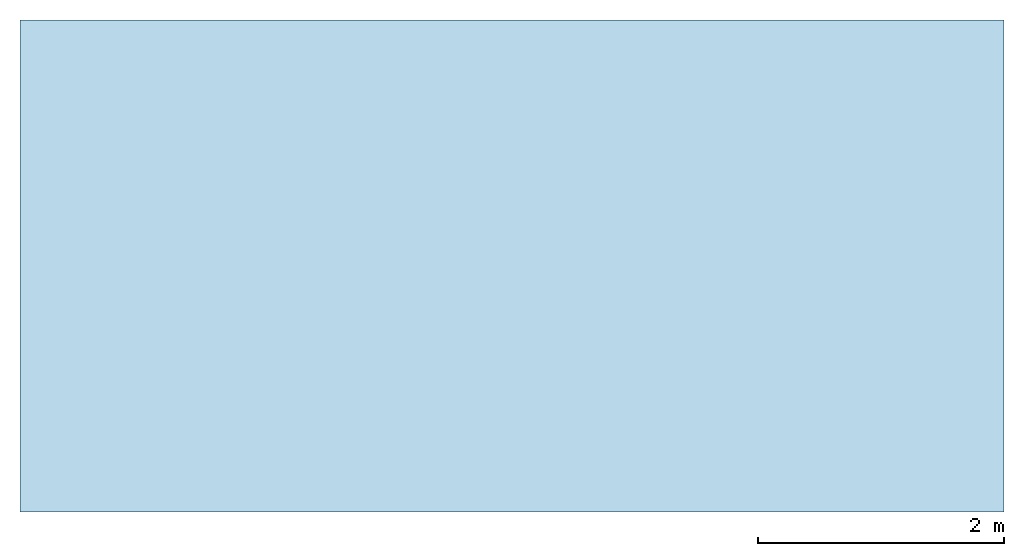
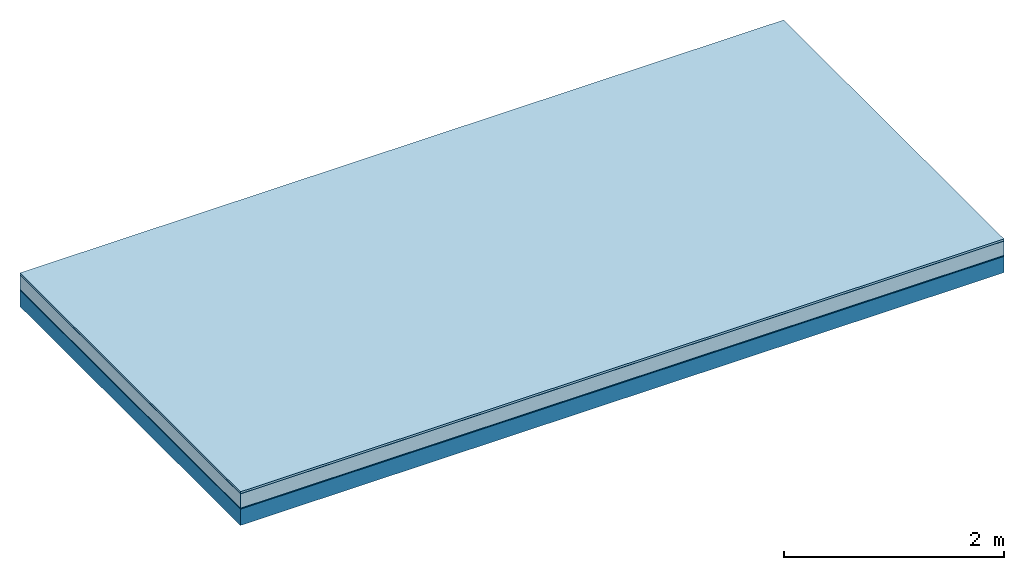
# One storey: 5 plates, 1 member, 1 element without a shape of its own.
"""IFC4 building model written with IfcOpenShell, lengths in metres."""

import ifcopenshell
import ifcopenshell.guid

model = None  # the IFC model being written
_history = None  # IfcOwnerHistory: only IFC2X3 demands one
_inside = {}  # id of a spatial element -> (the spatial element, [elements in it])
_under = {}  # id of a project, library or spatial element -> (it, [spatial elements below it])
_declared = {}  # id of a project -> (the project, [libraries it declares])
_typed = {}  # id of a type object -> (the type object, [elements of that type])
_made_of = {}  # id of a material, layer set ... -> (it, [elements and type objects made of it])


def new_model(schema):
    """Start an empty IFC model of exactly this schema.

    Asked for "IFC4X3", IfcOpenShell would pick the latest addendum, in which some entities
    have other attributes; the version numbers below select the first issue.
    IFC2X3 requires an IfcOwnerHistory on every rooted entity: one is made here for all.
    """
    global model, _history
    if schema == "IFC4X3":
        model = ifcopenshell.file(schema_version=(4, 3, 0, 0))
    else:
        model = ifcopenshell.file(schema=schema)
    _inside.clear()
    _under.clear()
    _declared.clear()
    _typed.clear()
    _made_of.clear()
    _history = None
    if model.schema == "IFC2X3":
        org = make("IfcOrganization", Name="unknown")
        user = make(
            "IfcPersonAndOrganization",
            ThePerson=make("IfcPerson", FamilyName="unknown"),
            TheOrganization=org,
        )
        app = make(
            "IfcApplication",
            ApplicationDeveloper=org,
            Version="unknown",
            ApplicationFullName="unknown",
            ApplicationIdentifier="unknown",
        )
        _history = make(
            "IfcOwnerHistory",
            OwningUser=user,
            OwningApplication=app,
            ChangeAction="ADDED",
            CreationDate=0,
        )
    return model


def make(cls, **values):
    """One entity of the class cls with the attributes given. An attribute that is None is left unset."""
    return model.create_entity(
        cls, **{name: value for name, value in values.items() if value is not None}
    )


def rooted(cls, **values):
    """An entity with a GlobalId (a new one), such as an element, a storey or a relation."""
    return make(cls, GlobalId=ifcopenshell.guid.new(), OwnerHistory=_history, **values)


def si_unit(unit_type, name, prefix=None):
    """IfcSIUnit, for example si_unit("LENGTHUNIT", "METRE", prefix="MILLI")."""
    return make("IfcSIUnit", UnitType=unit_type, Prefix=prefix, Name=name)


def derived_unit(unit_type, elements):
    """IfcDerivedUnit: a product of units, each with its exponent."""
    return make(
        "IfcDerivedUnit",
        Elements=[
            make("IfcDerivedUnitElement", Unit=unit, Exponent=power)
            for unit, power in elements
        ],
        UnitType=unit_type,
    )


def assignment(units):
    """IfcUnitAssignment: the units of a project."""
    return None if units is None else make("IfcUnitAssignment", Units=units)


def point(xyz):
    """IfcCartesianPoint."""
    return None if xyz is None else make("IfcCartesianPoint", Coordinates=xyz)


def direction(xyz):
    """IfcDirection."""
    return None if xyz is None else make("IfcDirection", DirectionRatios=xyz)


def frame(location, z_axis=None, x_axis=None):
    """IfcAxis2Placement3D, a coordinate frame: its origin and axes. An axis left out is left unset."""
    return make(
        "IfcAxis2Placement3D",
        Location=point(location),
        Axis=direction(z_axis),
        RefDirection=direction(x_axis),
    )


def frame_2d(location, x_axis=None):
    """IfcAxis2Placement2D, a coordinate frame in the plane: its origin and x axis."""
    return make(
        "IfcAxis2Placement2D", Location=point(location), RefDirection=direction(x_axis)
    )


def origin():
    """The frame at (0, 0, 0) with its axes left unset."""
    return frame((0.0, 0.0, 0.0))


def origin_with_axes():
    """The frame at (0, 0, 0) with the z axis (0, 0, 1) and the x axis (1, 0, 0) written out."""
    return frame((0.0, 0.0, 0.0), z_axis=(0.0, 0.0, 1.0), x_axis=(1.0, 0.0, 0.0))


def place(relative_to, where):
    """IfcLocalPlacement: puts the frame where relative to a parent placement (None: the world)."""
    return make(
        "IfcLocalPlacement", PlacementRelTo=relative_to, RelativePlacement=where
    )


def context(
    kind, dimensions, precision=None, world=None, true_north=None, identifier=None
):
    """IfcGeometricRepresentationContext, for example the 3D "Model" context."""
    return make(
        "IfcGeometricRepresentationContext",
        ContextIdentifier=identifier,
        ContextType=kind,
        CoordinateSpaceDimension=dimensions,
        Precision=precision,
        WorldCoordinateSystem=world,
        TrueNorth=true_north,
    )


def project(units=None, contexts=None):
    """IfcProject with its units and contexts."""
    return rooted(
        "IfcProject",
        Name="project",
        RepresentationContexts=contexts,
        UnitsInContext=assignment(units),
    )


def spatial(cls, under=None, at=None, **own):
    """A site, building, storey or space (cls), placed at a placement, below another one or the project."""
    s = rooted(cls, ObjectPlacement=at, **own)
    if under is not None:
        _under.setdefault(under.id(), (under, []))[1].append(s)
    return s


def profile(cls, at=None, kind="AREA", **sizes):
    """A parametric profile (cls). Its sizes go by their IFC names, for example OverallWidth=200.0."""
    return make(cls, ProfileType=kind, Position=at, **sizes)


def rectangle(**sizes):
    """IfcRectangleProfileDef."""
    return profile("IfcRectangleProfileDef", **sizes)


def extrude(swept, where, along, depth):
    """IfcExtrudedAreaSolid: the profile swept, set in the frame where, extruded along a direction by depth."""
    return make(
        "IfcExtrudedAreaSolid",
        SweptArea=swept,
        Position=where,
        ExtrudedDirection=direction(along),
        Depth=depth,
    )


def shape(context_of_items, identifier, shape_type, items):
    """IfcShapeRepresentation: the items that make up one representation, for example the "Body"."""
    return make(
        "IfcShapeRepresentation",
        ContextOfItems=context_of_items,
        RepresentationIdentifier=identifier,
        RepresentationType=shape_type,
        Items=items,
    )


def material(Name=None, Category=None):
    """IfcMaterial."""
    return make("IfcMaterial", Name=Name, Category=Category)


def layer(
    of_material, thickness, ventilated=None, Name=None, Category=None, Priority=None
):
    """IfcMaterialLayer: one layer of a wall or slab, of a material (None: an air gap)."""
    return make(
        "IfcMaterialLayer",
        Material=of_material,
        LayerThickness=thickness,
        IsVentilated=ventilated,
        Name=Name,
        Category=Category,
        Priority=Priority,
    )


def layer_set(layers, Name=None):
    """IfcMaterialLayerSet."""
    return make("IfcMaterialLayerSet", MaterialLayers=layers, LayerSetName=Name)


def made_of(thing, what):
    """Note that an element or type object is made of a material, layer set ...; save() writes the relation."""
    if what is not None:
        _made_of.setdefault(what.id(), (what, []))[1].append(thing)
    return thing


def type_object(cls, material=None, **own):
    """A type object (cls), such as IfcWallType, which elements share."""
    return made_of(rooted(cls, **own), material)


def element(
    cls,
    number,
    at=None,
    inside=None,
    cuts=None,
    type_object=None,
    material=None,
    context=None,
    identifier="Body",
    shape_type=None,
    held_by="IfcProductDefinitionShape",
    body=None,
    shapes=None,
    **own,
):
    """One element of the class cls, such as IfcWall. Its Tag is "e" and its number.

    at: its placement. inside: the storey or other place that contains it. cuts: it is an
    opening in that element (IfcRelVoidsElement). A single representation is given by context,
    identifier, shape_type and body (its items); several are given by shapes. held_by: the class
    of the entity that holds the representations. save() writes the other relations.
    """
    e = rooted(cls, Tag="e%d" % number, ObjectPlacement=at, **own)
    if body is not None:
        shapes = [shape(context, identifier, shape_type, body)]
    if shapes is not None:
        e.Representation = make(held_by, Representations=shapes)
    if inside is not None:
        _inside.setdefault(inside.id(), (inside, []))[1].append(e)
    if cuts is not None:
        rooted(
            "IfcRelVoidsElement", RelatingBuildingElement=cuts, RelatedOpeningElement=e
        )
    if type_object is not None:
        _typed.setdefault(type_object.id(), (type_object, []))[1].append(e)
    return made_of(e, material)


def aggregate(whole, parts):
    """IfcRelAggregates: a whole, such as a stair, and the parts it consists of."""
    return rooted("IfcRelAggregates", RelatingObject=whole, RelatedObjects=parts)


def save(model, path):
    """Write the relations noted so far, then the file.

    IfcRelAggregates (storeys below a building ...), IfcRelContainedInSpatialStructure (elements
    in a storey), IfcRelDefinesByType, IfcRelAssociatesMaterial and IfcRelDeclares: one each for
    every whole, place, type object, material and project.
    """
    for whole, parts in _under.values():
        aggregate(whole, parts)
    for where, things in _inside.values():
        rooted(
            "IfcRelContainedInSpatialStructure",
            RelatedElements=things,
            RelatingStructure=where,
        )
    for kind, things in _typed.values():
        rooted("IfcRelDefinesByType", RelatedObjects=things, RelatingType=kind)
    for what, things in _made_of.values():
        rooted("IfcRelAssociatesMaterial", RelatedObjects=things, RelatingMaterial=what)
    for by, libraries in _declared.values():
        rooted("IfcRelDeclares", RelatingContext=by, RelatedDefinitions=libraries)
    model.write(path)


model = new_model("IFC4")

# Units and contexts
plan_context = context("Plan", 3, precision=1e-05, world=origin(), true_north=direction((0.0, 1.0)))
model_context = context("Model", 3, precision=1e-05, world=origin(), true_north=direction((0.0, 1.0)))
ifc_project = project(units=[si_unit("LENGTHUNIT", "METRE"), derived_unit("SOUNDPRESSUREUNIT", [(si_unit("PRESSUREUNIT", "PASCAL", prefix="MICRO"), 0)]), si_unit("ENERGYUNIT", "JOULE", prefix="MEGA"), si_unit("MASSUNIT", "GRAM", prefix="KILO"), derived_unit("THERMALTRANSMITTANCEUNIT", [(si_unit("POWERUNIT", "WATT"), 1), (si_unit("AREAUNIT", "SQUARE_METRE"), -1), (si_unit("THERMODYNAMICTEMPERATUREUNIT", "KELVIN"), -1)]), derived_unit("AREADENSITYUNIT", [(si_unit("MASSUNIT", "GRAM", prefix="KILO"), 1), (si_unit("AREAUNIT", "SQUARE_METRE"), -1)]), derived_unit("USERDEFINED", [(si_unit("ENERGYUNIT", "JOULE", prefix="MEGA"), 1), (si_unit("AREAUNIT", "SQUARE_METRE"), -1)])], contexts=[plan_context, model_context])

# Site, building, storey
site = spatial("IfcSite", under=ifc_project)
building_placement = place(None, origin())
building = spatial("IfcBuilding", under=site, at=building_placement)
storey_placement = place(building_placement, origin())
storey = spatial("IfcBuildingStorey", under=building, at=storey_placement)

# Slab, member, plates
ifc_material_1 = material(Name="with tongue and groove", Category="07.009")
ifc_layer_1 = layer(ifc_material_1, 0.022, Name="Flooring")
ifc_material_2 = material(Category="09.006")
ifc_layer_2 = layer(ifc_material_2, 0.0005, Name="layer")
ifc_material_3 = material(Name="2x 60x80mm")
ifc_layer_3 = layer(ifc_material_3, 0.16, Name="On-material")
ifc_material_4 = material(Name="Wood fiber generic product", Category="10.009")
ifc_layer_4 = layer(ifc_material_4, 0.01, Name="Impact sound insulation")
ifc_material_5 = material(Name="protection", Category="09.007")
ifc_layer_5 = layer(ifc_material_5, 0.0005, Name="Sub-floor")
ifc_material_6 = material(Name="no composite action")
ifc_layer_6 = layer(ifc_material_6, 0.0, Name="Bond")
ifc_layer_7 = layer(None, 0.18, Name="Supporting structure")
ifc_layer_set = layer_set([ifc_layer_1, ifc_layer_2, ifc_layer_3, ifc_layer_4, ifc_layer_5, ifc_layer_6, ifc_layer_7])
slab_type = type_object("IfcSlabType", Name="A2027", PredefinedType="NOTDEFINED", material=ifc_layer_set)
slab_placement = place(None, frame((0.0, 0.0, 0.0), z_axis=(0.0, 0.0, -1.0), x_axis=(1.0, 0.0, 0.0)))
slab = element("IfcSlab", 1, at=slab_placement, inside=storey, type_object=slab_type, material=ifc_layer_set, Name="Slab #1")
ifc_material_7 = material(Name="Solid timber panel")
member_placement = place(slab_placement, origin())
member = element("IfcMember", 2, at=member_placement, material=ifc_material_7, Name="Supporting structure", context=plan_context, shape_type="SweptSolid", body=[
    extrude(rectangle(XDim=1.0, YDim=0.18, at=frame_2d((0.5, 0.09), x_axis=(1.0, 0.0))), frame((0.0, 4.0, 0.193), z_axis=(0.0, -1.0, 0.0), x_axis=(1.0, 0.0, 0.0)), (0.0, 0.0, 1.0), 4.0),
    extrude(rectangle(XDim=1.0, YDim=0.18, at=frame_2d((0.5, 0.09), x_axis=(1.0, 0.0))), frame((1.0, 4.0, 0.193), z_axis=(0.0, -1.0, 0.0), x_axis=(1.0, 0.0, 0.0)), (0.0, 0.0, 1.0), 4.0),
    extrude(rectangle(XDim=1.0, YDim=0.18, at=frame_2d((0.5, 0.09), x_axis=(1.0, 0.0))), frame((2.0, 4.0, 0.193), z_axis=(0.0, -1.0, 0.0), x_axis=(1.0, 0.0, 0.0)), (0.0, 0.0, 1.0), 4.0),
    extrude(rectangle(XDim=1.0, YDim=0.18, at=frame_2d((0.5, 0.09), x_axis=(1.0, 0.0))), frame((3.0, 4.0, 0.193), z_axis=(0.0, -1.0, 0.0), x_axis=(1.0, 0.0, 0.0)), (0.0, 0.0, 1.0), 4.0),
    extrude(rectangle(XDim=1.0, YDim=0.18, at=frame_2d((0.5, 0.09), x_axis=(1.0, 0.0))), frame((4.0, 4.0, 0.193), z_axis=(0.0, -1.0, 0.0), x_axis=(1.0, 0.0, 0.0)), (0.0, 0.0, 1.0), 4.0),
    extrude(rectangle(XDim=1.0, YDim=0.18, at=frame_2d((0.5, 0.09), x_axis=(1.0, 0.0))), frame((5.0, 4.0, 0.193), z_axis=(0.0, -1.0, 0.0), x_axis=(1.0, 0.0, 0.0)), (0.0, 0.0, 1.0), 4.0),
    extrude(rectangle(XDim=1.0, YDim=0.18, at=frame_2d((0.5, 0.09), x_axis=(1.0, 0.0))), frame((6.0, 4.0, 0.193), z_axis=(0.0, -1.0, 0.0), x_axis=(1.0, 0.0, 0.0)), (0.0, 0.0, 1.0), 4.0),
    extrude(rectangle(XDim=1.0, YDim=0.18, at=frame_2d((0.5, 0.09), x_axis=(1.0, 0.0))), frame((7.0, 4.0, 0.193), z_axis=(0.0, -1.0, 0.0), x_axis=(1.0, 0.0, 0.0)), (0.0, 0.0, 1.0), 4.0),
])
plate_1_placement = place(slab_placement, origin())
plate_1 = element("IfcPlate", 3, at=plate_1_placement, material=ifc_material_1, Name="Flooring", context=plan_context, shape_type="SweptSolid", body=[
    extrude(rectangle(XDim=8.0, YDim=4.0, at=frame_2d((4.0, 2.0), x_axis=(1.0, 0.0))), origin_with_axes(), (0.0, 0.0, 1.0), 0.022),
])
plate_2_placement = place(slab_placement, origin())
plate_2 = element("IfcPlate", 4, at=plate_2_placement, material=ifc_material_2, Name="layer", context=plan_context, shape_type="SweptSolid", body=[
    extrude(rectangle(XDim=8.0, YDim=4.0, at=frame_2d((4.0, 2.0), x_axis=(1.0, 0.0))), frame((0.0, 0.0, 0.022), z_axis=(0.0, 0.0, 1.0), x_axis=(1.0, 0.0, 0.0)), (0.0, 0.0, 1.0), 0.0005),
])
plate_3_placement = place(slab_placement, origin())
plate_3 = element("IfcPlate", 5, at=plate_3_placement, material=ifc_material_3, Name="On-material", context=plan_context, shape_type="SweptSolid", body=[
    extrude(rectangle(XDim=8.0, YDim=4.0, at=frame_2d((4.0, 2.0), x_axis=(1.0, 0.0))), frame((0.0, 0.0, 0.0225), z_axis=(0.0, 0.0, 1.0), x_axis=(1.0, 0.0, 0.0)), (0.0, 0.0, 1.0), 0.16),
])
plate_4_placement = place(slab_placement, origin())
plate_4 = element("IfcPlate", 6, at=plate_4_placement, material=ifc_material_4, Name="Impact sound insulation", context=plan_context, shape_type="SweptSolid", body=[
    extrude(rectangle(XDim=8.0, YDim=4.0, at=frame_2d((4.0, 2.0), x_axis=(1.0, 0.0))), frame((0.0, 0.0, 0.1825), z_axis=(0.0, 0.0, 1.0), x_axis=(1.0, 0.0, 0.0)), (0.0, 0.0, 1.0), 0.01),
])
plate_5_placement = place(slab_placement, origin())
plate_5 = element("IfcPlate", 7, at=plate_5_placement, material=ifc_material_5, Name="Sub-floor", context=plan_context, shape_type="SweptSolid", body=[
    extrude(rectangle(XDim=8.0, YDim=4.0, at=frame_2d((4.0, 2.0), x_axis=(1.0, 0.0))), frame((0.0, 0.0, 0.1925), z_axis=(0.0, 0.0, 1.0), x_axis=(1.0, 0.0, 0.0)), (0.0, 0.0, 1.0), 0.0005),
])
aggregate(slab, [plate_1, plate_2, plate_3, plate_4, plate_5, member])

save(model, "model.ifc")
